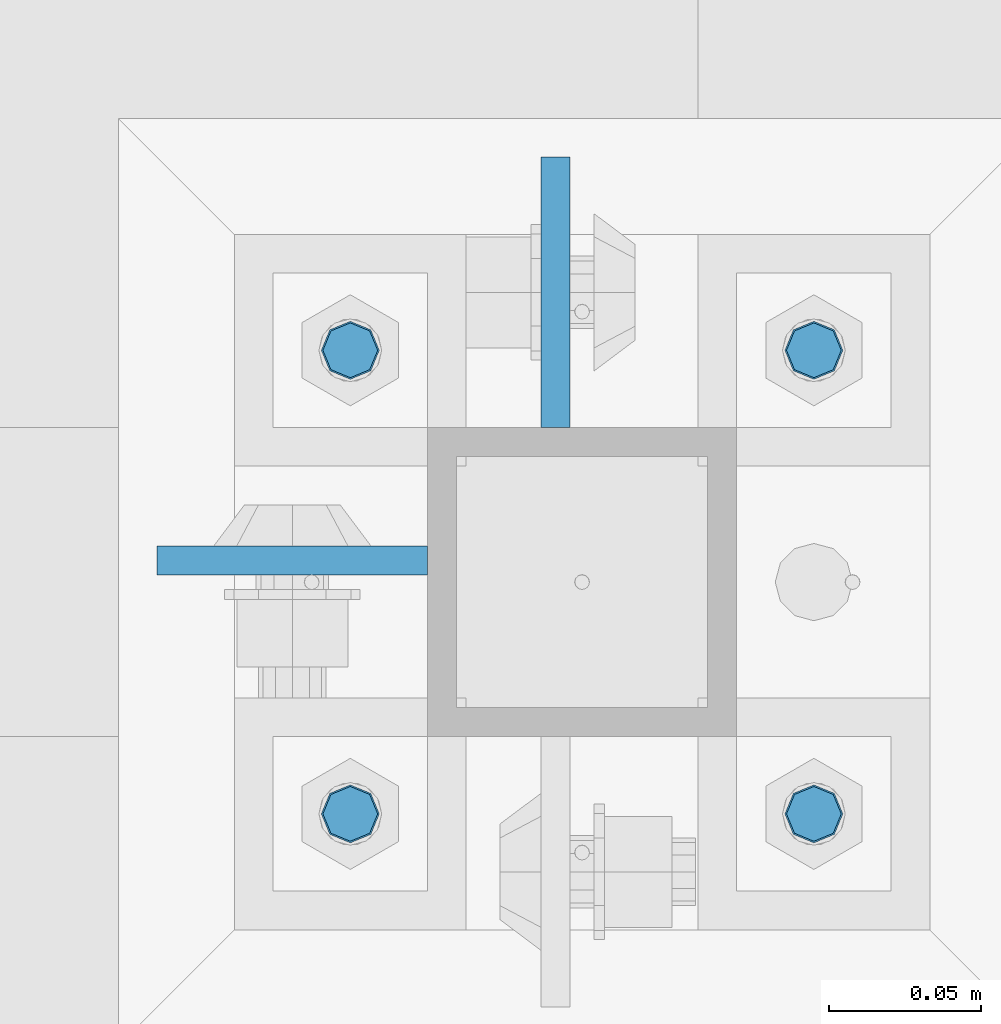
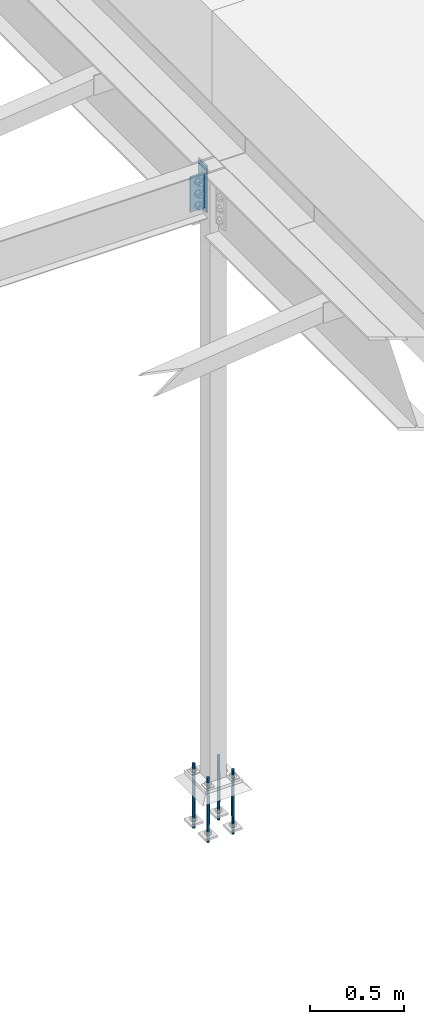
# One storey, part 1568 of 3843: 6 columns, 2 elements without a shape of their own.
"""IFC2X3 building model written with IfcOpenShell, lengths in millimetres."""

from ifc_helpers import new_model, si_unit, frame, origin_with_axes, place, context, subcontext, project, spatial, faceted_brep, material, type_object, element, aggregate, save


model = new_model("IFC2X3")

# Units and contexts
model_context = context("Model", 3, precision=1e-05, world=origin_with_axes())
body_context = subcontext(model_context, "Body", "Model", "MODEL_VIEW")
ifc_project = project(units=[si_unit("LENGTHUNIT", "METRE", prefix="MILLI"), si_unit("AREAUNIT", "SQUARE_METRE"), si_unit("VOLUMEUNIT", "CUBIC_METRE"), si_unit("MASSUNIT", "GRAM", prefix="KILO"), si_unit("TIMEUNIT", "SECOND"), si_unit("PLANEANGLEUNIT", "RADIAN"), si_unit("SOLIDANGLEUNIT", "STERADIAN"), si_unit("THERMODYNAMICTEMPERATUREUNIT", "DEGREE_CELSIUS"), si_unit("LUMINOUSINTENSITYUNIT", "LUMEN")], contexts=[model_context])

# Site, building, storey
site_placement = place(None, origin_with_axes())
site = spatial("IfcSite", under=ifc_project, at=site_placement, CompositionType="ELEMENT")
building_placement = place(site_placement, origin_with_axes())
building = spatial("IfcBuilding", under=site, at=building_placement, Name="Undefined", CompositionType="ELEMENT")
storey_placement = place(building_placement, origin_with_axes())
storey = spatial("IfcBuildingStorey", under=building, at=storey_placement, Name="Undefined", CompositionType="ELEMENT", Elevation=0.0)

# Assembly, columns
assembly_1_placement = place(storey_placement, origin_with_axes())
assembly_1 = element("IfcElementAssembly", 1, at=assembly_1_placement, inside=storey, Name="COLUMN", AssemblyPlace="NOTDEFINED", PredefinedType="RIGID_FRAME")
ifc_material_1 = material(Name="STEEL/A572-50")
column_type_1 = type_object("IfcColumnType", PredefinedType="NOTDEFINED")
column_1_placement = place(assembly_1_placement, frame((38811.9945000649, 84080.35, 33693.0999993376), z_axis=(0.0, -1.0, 0.0), x_axis=(0.0, 0.0, 1.0)))
column_1 = element("IfcColumn", 2, at=column_1_placement, type_object=column_type_1, material=ifc_material_1, Name="PLATE", context=body_context, shape_type="Brep", body=[
    faceted_brep([(0.0, 4.76249999999709, -44.4500000000007), (0.0, 4.76249999999709, 44.4500000000007), (304.799999999996, 4.76249999999709, 44.4500000000007), (304.799999999996, 4.76249999999709, -44.4500000000007), (0.0, -4.76249999999709, 44.4500000000007), (304.799999999996, -4.76249999999709, 44.4500000000007), (0.0, -4.76249999999709, -44.4500000000007), (304.799999999996, -4.76249999999709, -44.4500000000007)], [[[0, 1, 2, 3]], [[1, 4, 5, 2]], [[4, 6, 7, 5]], [[6, 0, 3, 7]], [[5, 7, 3, 2]], [[6, 4, 1, 0]]]),
])
column_2_placement = place(assembly_1_placement, frame((38725.475, 83992.243500042, 33769.3), z_axis=(1.0, 0.0, 0.0), x_axis=(0.0, 0.0, 1.0)))
column_2 = element("IfcColumn", 3, at=column_2_placement, type_object=column_type_1, material=ifc_material_1, Name="PLATE", context=body_context, shape_type="Brep", body=[
    faceted_brep([(0.0, 4.76249999999709, -44.4500000000007), (0.0, 4.76249999999709, 44.4500000000007), (228.599999999999, 4.76249999999709, 44.4500000000007), (228.599999999999, 4.76249999999709, -44.4500000000007), (0.0, -4.76249999999709, 44.4500000000007), (228.599999999999, -4.76249999999709, 44.4500000000007), (0.0, -4.76249999999709, -44.4500000000007), (228.599999999999, -4.76249999999709, -44.4500000000007)], [[[0, 1, 2, 3]], [[1, 4, 5, 2]], [[4, 6, 7, 5]], [[6, 0, 3, 7]], [[5, 7, 3, 2]], [[6, 4, 1, 0]]]),
])
aggregate(assembly_1, [column_1, column_2])

assembly_2_placement = place(storey_placement, origin_with_axes())
assembly_2 = element("IfcElementAssembly", 4, at=assembly_2_placement, inside=storey, Name="TEMPLATE", AssemblyPlace="NOTDEFINED", PredefinedType="RIGID_FRAME")
ifc_material_2 = material(Name="Undefined/F1554-GR.55")
column_type_2 = type_object("IfcColumnType", PredefinedType="NOTDEFINED")
column_3_placement = place(assembly_2_placement, frame((38896.925, 83908.9, 30022.8), z_axis=(1.0, 0.0, 0.0), x_axis=(0.0, 0.0, -1.0)))
column_3 = element("IfcColumn", 5, at=column_3_placement, type_object=column_type_2, material=ifc_material_2, Name="ANCHOR_ROD", context=body_context, shape_type="Brep", body=[
    faceted_brep([(-114.300000000003, -6.36396103068546, 6.36396103067818), (-114.300000000003, 0.0, 9.0), (-114.300000000003, 6.36396103068546, 6.36396103067818), (-114.300000000003, 9.0, 0.0), (-114.300000000003, 6.36396103068546, -6.36396103067818), (-114.300000000003, 0.0, -9.0), (-114.300000000003, -6.36396103068546, -6.36396103067818), (-114.300000000003, -9.0, 0.0), (0.0, 6.36396103068546, -6.36396103067818), (0.0, 0.0, -9.0), (0.0, -6.36396103068546, -6.36396103067818), (0.0, -9.0, 0.0), (0.0, -6.36396103068546, 6.36396103067818), (0.0, 0.0, 9.0), (0.0, 6.36396103068546, 6.36396103067818), (0.0, 9.0, 0.0), (0.0, -6.73519209080405, 6.73519209079677), (-9.87109982941227e-13, 2.91322521661641e-12, 9.52499961853027), (0.0, 6.73519209080405, 6.73519209079677), (0.0, 9.52500000000146, 0.0), (0.0, 6.73519209080405, -6.73519209079677), (2.95075507493764e-12, 2.91322521661641e-12, -9.52499961853027), (0.0, -6.73519209080405, -6.73519209079677), (0.0, -9.52500000000146, 0.0), (190.5, -9.52499999999418, 0.0), (190.5, -6.73519209079677, 6.73519209080405), (190.5, 0.0, 9.52500000000146), (190.5, 6.73519209079677, 6.73519209080405), (190.5, 9.52499999999418, 0.0), (190.5, 6.73519209079677, -6.73519209080405), (190.5, 0.0, -9.52500000000146), (190.5, -6.73519209079677, -6.73519209080405), (190.5, -6.36396103068546, 6.36396103067818), (190.5, 0.0, 9.0), (190.5, 6.36396103068546, 6.36396103067818), (190.5, 9.0, 0.0), (190.5, 6.36396103068546, -6.36396103067818), (190.5, 0.0, -9.0), (190.5, -6.36396103068546, -6.36396103067818), (190.5, -9.0, 0.0), (304.799999999999, 0.0, -9.0), (304.799999999999, 6.36396103068546, -6.36396103067818), (304.799999999999, 9.0, 0.0), (304.799999999999, 6.36396103068546, 6.36396103067818), (304.799999999999, 0.0, 9.0), (304.799999999999, -6.36396103068546, 6.36396103067818), (304.799999999999, -9.0, 0.0), (304.799999999999, -6.36396103068546, -6.36396103067818)], [[[0, 1, 2, 3, 4, 5, 6, 7]], [[5, 4, 8, 9]], [[6, 5, 9, 10]], [[7, 6, 10, 11]], [[0, 7, 11, 12]], [[1, 0, 12, 13]], [[2, 1, 13, 14]], [[3, 2, 14, 15]], [[4, 3, 15, 8]], [[16, 17, 18, 19, 20, 21, 22, 23], [14, 13, 12, 11, 10, 9, 8, 15]], [[16, 23, 24, 25]], [[17, 16, 25, 26]], [[18, 17, 26, 27]], [[19, 18, 27, 28]], [[20, 19, 28, 29]], [[21, 20, 29, 30]], [[22, 21, 30, 31]], [[23, 22, 31, 24]], [[30, 29, 28, 27, 26, 25, 24, 31], [32, 33, 34, 35, 36, 37, 38, 39]], [[40, 41, 42, 43, 44, 45, 46, 47]], [[45, 44, 33, 32]], [[46, 45, 32, 39]], [[47, 46, 39, 38]], [[40, 47, 38, 37]], [[41, 40, 37, 36]], [[42, 41, 36, 35]], [[43, 42, 35, 34]], [[44, 43, 34, 33]]]),
])
column_4_placement = place(assembly_2_placement, frame((38896.925, 84061.3, 30022.8), z_axis=(-1.0, 0.0, 0.0), x_axis=(0.0, 0.0, -1.0)))
column_4 = element("IfcColumn", 6, at=column_4_placement, type_object=column_type_2, material=ifc_material_2, Name="ANCHOR_ROD", context=body_context, shape_type="Brep", body=[
    faceted_brep([(-114.300000000003, -6.36396103068546, 6.36396103067818), (-114.300000000003, 0.0, 9.0), (-114.300000000003, 6.36396103068546, 6.36396103067818), (-114.300000000003, 9.0, 0.0), (-114.300000000003, 6.36396103068546, -6.36396103067818), (-114.300000000003, 0.0, -9.0), (-114.300000000003, -6.36396103068546, -6.36396103067818), (-114.300000000003, -9.0, 0.0), (0.0, 6.36396103068546, -6.36396103067818), (0.0, 0.0, -9.0), (0.0, -6.36396103068546, -6.36396103067818), (0.0, -9.0, 0.0), (0.0, -6.36396103068546, 6.36396103067818), (0.0, 0.0, 9.0), (0.0, 6.36396103068546, 6.36396103067818), (0.0, 9.0, 0.0), (0.0, -6.73519209080405, 6.73519209079677), (-9.87109982941227e-13, 2.91322521661641e-12, 9.52499961853027), (0.0, 6.73519209080405, 6.73519209079677), (0.0, 9.52500000000146, 0.0), (0.0, 6.73519209080405, -6.73519209079677), (2.95075507493764e-12, 2.91322521661641e-12, -9.52499961853027), (0.0, -6.73519209080405, -6.73519209079677), (0.0, -9.52500000000146, 0.0), (190.5, -9.52499999999418, 0.0), (190.5, -6.73519209079677, 6.73519209080405), (190.5, 0.0, 9.52500000000146), (190.5, 6.73519209079677, 6.73519209080405), (190.5, 9.52499999999418, 0.0), (190.5, 6.73519209079677, -6.73519209080405), (190.5, 0.0, -9.52500000000146), (190.5, -6.73519209079677, -6.73519209080405), (190.5, -6.36396103068546, 6.36396103067818), (190.5, 0.0, 9.0), (190.5, 6.36396103068546, 6.36396103067818), (190.5, 9.0, 0.0), (190.5, 6.36396103068546, -6.36396103067818), (190.5, 0.0, -9.0), (190.5, -6.36396103068546, -6.36396103067818), (190.5, -9.0, 0.0), (304.799999999999, 0.0, -9.0), (304.799999999999, 6.36396103068546, -6.36396103067818), (304.799999999999, 9.0, 0.0), (304.799999999999, 6.36396103068546, 6.36396103067818), (304.799999999999, 0.0, 9.0), (304.799999999999, -6.36396103068546, 6.36396103067818), (304.799999999999, -9.0, 0.0), (304.799999999999, -6.36396103068546, -6.36396103067818)], [[[0, 1, 2, 3, 4, 5, 6, 7]], [[5, 4, 8, 9]], [[6, 5, 9, 10]], [[7, 6, 10, 11]], [[0, 7, 11, 12]], [[1, 0, 12, 13]], [[2, 1, 13, 14]], [[3, 2, 14, 15]], [[4, 3, 15, 8]], [[16, 17, 18, 19, 20, 21, 22, 23], [14, 13, 12, 11, 10, 9, 8, 15]], [[16, 23, 24, 25]], [[17, 16, 25, 26]], [[18, 17, 26, 27]], [[19, 18, 27, 28]], [[20, 19, 28, 29]], [[21, 20, 29, 30]], [[22, 21, 30, 31]], [[23, 22, 31, 24]], [[30, 29, 28, 27, 26, 25, 24, 31], [32, 33, 34, 35, 36, 37, 38, 39]], [[40, 41, 42, 43, 44, 45, 46, 47]], [[45, 44, 33, 32]], [[46, 45, 32, 39]], [[47, 46, 39, 38]], [[40, 47, 38, 37]], [[41, 40, 37, 36]], [[42, 41, 36, 35]], [[43, 42, 35, 34]], [[44, 43, 34, 33]]]),
])
column_5_placement = place(assembly_2_placement, frame((38744.525, 83908.9, 30022.8), z_axis=(1.0, 0.0, 0.0), x_axis=(0.0, 0.0, -1.0)))
column_5 = element("IfcColumn", 7, at=column_5_placement, type_object=column_type_2, material=ifc_material_2, Name="ANCHOR_ROD", context=body_context, shape_type="Brep", body=[
    faceted_brep([(-114.300000000003, -6.36396103068546, 6.36396103067818), (-114.300000000003, 0.0, 9.0), (-114.300000000003, 6.36396103068546, 6.36396103067818), (-114.300000000003, 9.0, 0.0), (-114.300000000003, 6.36396103068546, -6.36396103067818), (-114.300000000003, 0.0, -9.0), (-114.300000000003, -6.36396103068546, -6.36396103067818), (-114.300000000003, -9.0, 0.0), (0.0, 6.36396103068546, -6.36396103067818), (0.0, 0.0, -9.0), (0.0, -6.36396103068546, -6.36396103067818), (0.0, -9.0, 0.0), (0.0, -6.36396103068546, 6.36396103067818), (0.0, 0.0, 9.0), (0.0, 6.36396103068546, 6.36396103067818), (0.0, 9.0, 0.0), (0.0, -6.73519209080405, 6.73519209079677), (-9.87109982941227e-13, 2.91322521661641e-12, 9.52499961853027), (0.0, 6.73519209080405, 6.73519209079677), (0.0, 9.52500000000146, 0.0), (0.0, 6.73519209080405, -6.73519209079677), (2.95075507493764e-12, 2.91322521661641e-12, -9.52499961853027), (0.0, -6.73519209080405, -6.73519209079677), (0.0, -9.52500000000146, 0.0), (190.5, -9.52499999999418, 0.0), (190.5, -6.73519209079677, 6.73519209080405), (190.5, 0.0, 9.52500000000146), (190.5, 6.73519209079677, 6.73519209080405), (190.5, 9.52499999999418, 0.0), (190.5, 6.73519209079677, -6.73519209080405), (190.5, 0.0, -9.52500000000146), (190.5, -6.73519209079677, -6.73519209080405), (190.5, -6.36396103068546, 6.36396103067818), (190.5, 0.0, 9.0), (190.5, 6.36396103068546, 6.36396103067818), (190.5, 9.0, 0.0), (190.5, 6.36396103068546, -6.36396103067818), (190.5, 0.0, -9.0), (190.5, -6.36396103068546, -6.36396103067818), (190.5, -9.0, 0.0), (304.799999999999, 0.0, -9.0), (304.799999999999, 6.36396103068546, -6.36396103067818), (304.799999999999, 9.0, 0.0), (304.799999999999, 6.36396103068546, 6.36396103067818), (304.799999999999, 0.0, 9.0), (304.799999999999, -6.36396103068546, 6.36396103067818), (304.799999999999, -9.0, 0.0), (304.799999999999, -6.36396103068546, -6.36396103067818)], [[[0, 1, 2, 3, 4, 5, 6, 7]], [[5, 4, 8, 9]], [[6, 5, 9, 10]], [[7, 6, 10, 11]], [[0, 7, 11, 12]], [[1, 0, 12, 13]], [[2, 1, 13, 14]], [[3, 2, 14, 15]], [[4, 3, 15, 8]], [[16, 17, 18, 19, 20, 21, 22, 23], [14, 13, 12, 11, 10, 9, 8, 15]], [[16, 23, 24, 25]], [[17, 16, 25, 26]], [[18, 17, 26, 27]], [[19, 18, 27, 28]], [[20, 19, 28, 29]], [[21, 20, 29, 30]], [[22, 21, 30, 31]], [[23, 22, 31, 24]], [[30, 29, 28, 27, 26, 25, 24, 31], [32, 33, 34, 35, 36, 37, 38, 39]], [[40, 41, 42, 43, 44, 45, 46, 47]], [[45, 44, 33, 32]], [[46, 45, 32, 39]], [[47, 46, 39, 38]], [[40, 47, 38, 37]], [[41, 40, 37, 36]], [[42, 41, 36, 35]], [[43, 42, 35, 34]], [[44, 43, 34, 33]]]),
])
column_6_placement = place(assembly_2_placement, frame((38744.525, 84061.3, 30022.8), z_axis=(-1.0, 0.0, 0.0), x_axis=(0.0, 0.0, -1.0)))
column_6 = element("IfcColumn", 8, at=column_6_placement, type_object=column_type_2, material=ifc_material_2, Name="ANCHOR_ROD", context=body_context, shape_type="Brep", body=[
    faceted_brep([(-114.300000000003, -6.36396103068546, 6.36396103067818), (-114.300000000003, 0.0, 9.0), (-114.300000000003, 6.36396103068546, 6.36396103067818), (-114.300000000003, 9.0, 0.0), (-114.300000000003, 6.36396103068546, -6.36396103067818), (-114.300000000003, 0.0, -9.0), (-114.300000000003, -6.36396103068546, -6.36396103067818), (-114.300000000003, -9.0, 0.0), (0.0, 6.36396103068546, -6.36396103067818), (0.0, 0.0, -9.0), (0.0, -6.36396103068546, -6.36396103067818), (0.0, -9.0, 0.0), (0.0, -6.36396103068546, 6.36396103067818), (0.0, 0.0, 9.0), (0.0, 6.36396103068546, 6.36396103067818), (0.0, 9.0, 0.0), (0.0, -6.73519209080405, 6.73519209079677), (-9.87109982941227e-13, 2.91322521661641e-12, 9.52499961853027), (0.0, 6.73519209080405, 6.73519209079677), (0.0, 9.52500000000146, 0.0), (0.0, 6.73519209080405, -6.73519209079677), (2.95075507493764e-12, 2.91322521661641e-12, -9.52499961853027), (0.0, -6.73519209080405, -6.73519209079677), (0.0, -9.52500000000146, 0.0), (190.5, -9.52499999999418, 0.0), (190.5, -6.73519209079677, 6.73519209080405), (190.5, 0.0, 9.52500000000146), (190.5, 6.73519209079677, 6.73519209080405), (190.5, 9.52499999999418, 0.0), (190.5, 6.73519209079677, -6.73519209080405), (190.5, 0.0, -9.52500000000146), (190.5, -6.73519209079677, -6.73519209080405), (190.5, -6.36396103068546, 6.36396103067818), (190.5, 0.0, 9.0), (190.5, 6.36396103068546, 6.36396103067818), (190.5, 9.0, 0.0), (190.5, 6.36396103068546, -6.36396103067818), (190.5, 0.0, -9.0), (190.5, -6.36396103068546, -6.36396103067818), (190.5, -9.0, 0.0), (304.799999999999, 0.0, -9.0), (304.799999999999, 6.36396103068546, -6.36396103067818), (304.799999999999, 9.0, 0.0), (304.799999999999, 6.36396103068546, 6.36396103067818), (304.799999999999, 0.0, 9.0), (304.799999999999, -6.36396103068546, 6.36396103067818), (304.799999999999, -9.0, 0.0), (304.799999999999, -6.36396103068546, -6.36396103067818)], [[[0, 1, 2, 3, 4, 5, 6, 7]], [[5, 4, 8, 9]], [[6, 5, 9, 10]], [[7, 6, 10, 11]], [[0, 7, 11, 12]], [[1, 0, 12, 13]], [[2, 1, 13, 14]], [[3, 2, 14, 15]], [[4, 3, 15, 8]], [[16, 17, 18, 19, 20, 21, 22, 23], [14, 13, 12, 11, 10, 9, 8, 15]], [[16, 23, 24, 25]], [[17, 16, 25, 26]], [[18, 17, 26, 27]], [[19, 18, 27, 28]], [[20, 19, 28, 29]], [[21, 20, 29, 30]], [[22, 21, 30, 31]], [[23, 22, 31, 24]], [[30, 29, 28, 27, 26, 25, 24, 31], [32, 33, 34, 35, 36, 37, 38, 39]], [[40, 41, 42, 43, 44, 45, 46, 47]], [[45, 44, 33, 32]], [[46, 45, 32, 39]], [[47, 46, 39, 38]], [[40, 47, 38, 37]], [[41, 40, 37, 36]], [[42, 41, 36, 35]], [[43, 42, 35, 34]], [[44, 43, 34, 33]]]),
])
aggregate(assembly_2, [column_3, column_4, column_5, column_6])

save(model, "model.ifc")
